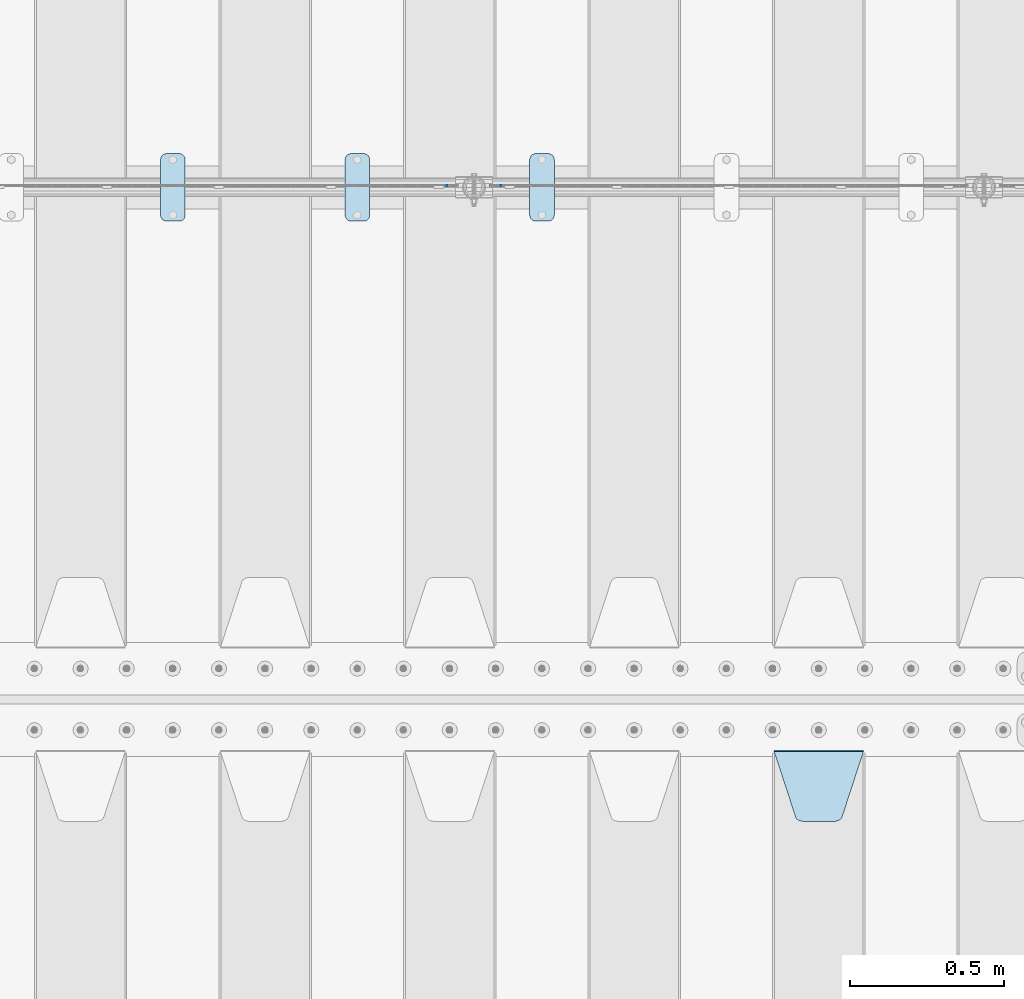
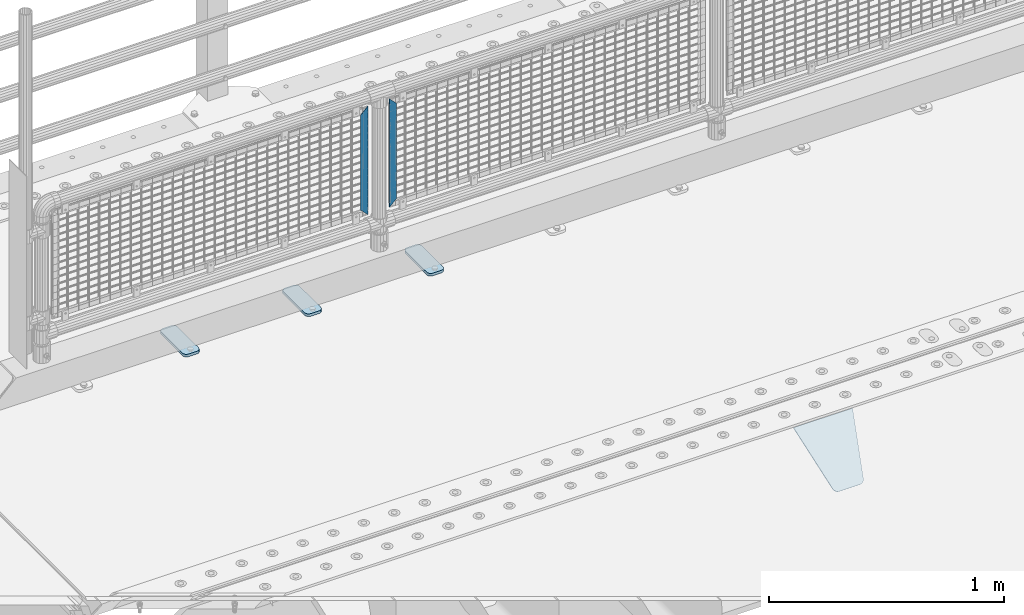
# One storey, part 211 of 240: 6 plates.
"""IFC2X3 building model written with IfcOpenShell, lengths in millimetres."""

import ifcopenshell
import ifcopenshell.guid

model = None  # the IFC model being written
_history = None  # IfcOwnerHistory: only IFC2X3 demands one
_inside = {}  # id of a spatial element -> (the spatial element, [elements in it])
_under = {}  # id of a project, library or spatial element -> (it, [spatial elements below it])
_declared = {}  # id of a project -> (the project, [libraries it declares])
_typed = {}  # id of a type object -> (the type object, [elements of that type])
_made_of = {}  # id of a material, layer set ... -> (it, [elements and type objects made of it])


def new_model(schema):
    """Start an empty IFC model of exactly this schema.

    Asked for "IFC4X3", IfcOpenShell would pick the latest addendum, in which some entities
    have other attributes; the version numbers below select the first issue.
    IFC2X3 requires an IfcOwnerHistory on every rooted entity: one is made here for all.
    """
    global model, _history
    if schema == "IFC4X3":
        model = ifcopenshell.file(schema_version=(4, 3, 0, 0))
    else:
        model = ifcopenshell.file(schema=schema)
    _inside.clear()
    _under.clear()
    _declared.clear()
    _typed.clear()
    _made_of.clear()
    _history = None
    if model.schema == "IFC2X3":
        org = make("IfcOrganization", Name="unknown")
        user = make(
            "IfcPersonAndOrganization",
            ThePerson=make("IfcPerson", FamilyName="unknown"),
            TheOrganization=org,
        )
        app = make(
            "IfcApplication",
            ApplicationDeveloper=org,
            Version="unknown",
            ApplicationFullName="unknown",
            ApplicationIdentifier="unknown",
        )
        _history = make(
            "IfcOwnerHistory",
            OwningUser=user,
            OwningApplication=app,
            ChangeAction="ADDED",
            CreationDate=0,
        )
    return model


def make(cls, **values):
    """One entity of the class cls with the attributes given. An attribute that is None is left unset."""
    return model.create_entity(
        cls, **{name: value for name, value in values.items() if value is not None}
    )


def rooted(cls, **values):
    """An entity with a GlobalId (a new one), such as an element, a storey or a relation."""
    return make(cls, GlobalId=ifcopenshell.guid.new(), OwnerHistory=_history, **values)


def si_unit(unit_type, name, prefix=None):
    """IfcSIUnit, for example si_unit("LENGTHUNIT", "METRE", prefix="MILLI")."""
    return make("IfcSIUnit", UnitType=unit_type, Prefix=prefix, Name=name)


def assignment(units):
    """IfcUnitAssignment: the units of a project."""
    return None if units is None else make("IfcUnitAssignment", Units=units)


def point(xyz):
    """IfcCartesianPoint."""
    return None if xyz is None else make("IfcCartesianPoint", Coordinates=xyz)


def direction(xyz):
    """IfcDirection."""
    return None if xyz is None else make("IfcDirection", DirectionRatios=xyz)


def frame(location, z_axis=None, x_axis=None):
    """IfcAxis2Placement3D, a coordinate frame: its origin and axes. An axis left out is left unset."""
    return make(
        "IfcAxis2Placement3D",
        Location=point(location),
        Axis=direction(z_axis),
        RefDirection=direction(x_axis),
    )


def origin_with_axes():
    """The frame at (0, 0, 0) with the z axis (0, 0, 1) and the x axis (1, 0, 0) written out."""
    return frame((0.0, 0.0, 0.0), z_axis=(0.0, 0.0, 1.0), x_axis=(1.0, 0.0, 0.0))


def place(relative_to, where):
    """IfcLocalPlacement: puts the frame where relative to a parent placement (None: the world)."""
    return make(
        "IfcLocalPlacement", PlacementRelTo=relative_to, RelativePlacement=where
    )


def context(
    kind, dimensions, precision=None, world=None, true_north=None, identifier=None
):
    """IfcGeometricRepresentationContext, for example the 3D "Model" context."""
    return make(
        "IfcGeometricRepresentationContext",
        ContextIdentifier=identifier,
        ContextType=kind,
        CoordinateSpaceDimension=dimensions,
        Precision=precision,
        WorldCoordinateSystem=world,
        TrueNorth=true_north,
    )


def subcontext(parent, identifier, kind, view, scale=None):
    """IfcGeometricRepresentationSubContext, for example "Body" below "Model"."""
    return make(
        "IfcGeometricRepresentationSubContext",
        ContextIdentifier=identifier,
        ContextType=kind,
        ParentContext=parent,
        TargetScale=scale,
        TargetView=view,
    )


def project(units=None, contexts=None):
    """IfcProject with its units and contexts."""
    return rooted(
        "IfcProject",
        Name="project",
        RepresentationContexts=contexts,
        UnitsInContext=assignment(units),
    )


def spatial(cls, under=None, at=None, **own):
    """A site, building, storey or space (cls), placed at a placement, below another one or the project."""
    s = rooted(cls, ObjectPlacement=at, **own)
    if under is not None:
        _under.setdefault(under.id(), (under, []))[1].append(s)
    return s


def faces_of(points, faces, orient=None, outer=None):
    """IfcFace entities. A face is a list of loops; a loop is a list of indices into points, from 0.

    orient and outer hold one flag for each loop. By default every Orientation is true, the
    first loop of a face is its IfcFaceOuterBound and the others are IfcFaceBound.
    """
    made = []
    for i, loops in enumerate(faces):
        bounds = []
        for j, loop in enumerate(loops):
            is_outer = j == 0 if outer is None else outer[i][j]
            bounds.append(
                make(
                    "IfcFaceOuterBound" if is_outer else "IfcFaceBound",
                    Bound=make("IfcPolyLoop", Polygon=[points[k] for k in loop]),
                    Orientation=True if orient is None else orient[i][j],
                )
            )
        made.append(make("IfcFace", Bounds=bounds))
    return made


def faceted_brep(points, faces, orient=None, outer=None, voids=None):
    """IfcFacetedBrep: a solid bounded by flat faces; with voids (closed shells), ...WithVoids."""
    shared = [point(p) for p in points]
    hull = make("IfcClosedShell", CfsFaces=faces_of(shared, faces, orient, outer))
    if voids is None:
        return make("IfcFacetedBrep", Outer=hull)
    return make(
        "IfcFacetedBrepWithVoids",
        Outer=hull,
        Voids=[
            make(cls, CfsFaces=faces_of(shared, fs, o, b)) for cls, fs, o, b in voids
        ],
    )


def shape(context_of_items, identifier, shape_type, items):
    """IfcShapeRepresentation: the items that make up one representation, for example the "Body"."""
    return make(
        "IfcShapeRepresentation",
        ContextOfItems=context_of_items,
        RepresentationIdentifier=identifier,
        RepresentationType=shape_type,
        Items=items,
    )


def material(Name=None, Category=None):
    """IfcMaterial."""
    return make("IfcMaterial", Name=Name, Category=Category)


def made_of(thing, what):
    """Note that an element or type object is made of a material, layer set ...; save() writes the relation."""
    if what is not None:
        _made_of.setdefault(what.id(), (what, []))[1].append(thing)
    return thing


def type_object(cls, material=None, **own):
    """A type object (cls), such as IfcWallType, which elements share."""
    return made_of(rooted(cls, **own), material)


def element(
    cls,
    number,
    at=None,
    inside=None,
    cuts=None,
    type_object=None,
    material=None,
    context=None,
    identifier="Body",
    shape_type=None,
    held_by="IfcProductDefinitionShape",
    body=None,
    shapes=None,
    **own,
):
    """One element of the class cls, such as IfcWall. Its Tag is "e" and its number.

    at: its placement. inside: the storey or other place that contains it. cuts: it is an
    opening in that element (IfcRelVoidsElement). A single representation is given by context,
    identifier, shape_type and body (its items); several are given by shapes. held_by: the class
    of the entity that holds the representations. save() writes the other relations.
    """
    e = rooted(cls, Tag="e%d" % number, ObjectPlacement=at, **own)
    if body is not None:
        shapes = [shape(context, identifier, shape_type, body)]
    if shapes is not None:
        e.Representation = make(held_by, Representations=shapes)
    if inside is not None:
        _inside.setdefault(inside.id(), (inside, []))[1].append(e)
    if cuts is not None:
        rooted(
            "IfcRelVoidsElement", RelatingBuildingElement=cuts, RelatedOpeningElement=e
        )
    if type_object is not None:
        _typed.setdefault(type_object.id(), (type_object, []))[1].append(e)
    return made_of(e, material)


def aggregate(whole, parts):
    """IfcRelAggregates: a whole, such as a stair, and the parts it consists of."""
    return rooted("IfcRelAggregates", RelatingObject=whole, RelatedObjects=parts)


def save(model, path):
    """Write the relations noted so far, then the file.

    IfcRelAggregates (storeys below a building ...), IfcRelContainedInSpatialStructure (elements
    in a storey), IfcRelDefinesByType, IfcRelAssociatesMaterial and IfcRelDeclares: one each for
    every whole, place, type object, material and project.
    """
    for whole, parts in _under.values():
        aggregate(whole, parts)
    for where, things in _inside.values():
        rooted(
            "IfcRelContainedInSpatialStructure",
            RelatedElements=things,
            RelatingStructure=where,
        )
    for kind, things in _typed.values():
        rooted("IfcRelDefinesByType", RelatedObjects=things, RelatingType=kind)
    for what, things in _made_of.values():
        rooted("IfcRelAssociatesMaterial", RelatedObjects=things, RelatingMaterial=what)
    for by, libraries in _declared.values():
        rooted("IfcRelDeclares", RelatingContext=by, RelatedDefinitions=libraries)
    model.write(path)


model = new_model("IFC2X3")

# Units and contexts
model_context = context("Model", 3, precision=1e-05, world=origin_with_axes())
body_context = subcontext(model_context, "Body", "Model", "MODEL_VIEW")
ifc_project = project(units=[si_unit("LENGTHUNIT", "METRE", prefix="MILLI"), si_unit("AREAUNIT", "SQUARE_METRE"), si_unit("VOLUMEUNIT", "CUBIC_METRE"), si_unit("MASSUNIT", "GRAM", prefix="KILO"), si_unit("TIMEUNIT", "SECOND"), si_unit("PLANEANGLEUNIT", "RADIAN"), si_unit("SOLIDANGLEUNIT", "STERADIAN"), si_unit("THERMODYNAMICTEMPERATUREUNIT", "DEGREE_CELSIUS"), si_unit("LUMINOUSINTENSITYUNIT", "LUMEN")], contexts=[model_context])

# Site, building, storey
site_placement = place(None, origin_with_axes())
site = spatial("IfcSite", under=ifc_project, at=site_placement, CompositionType="ELEMENT")
building_placement = place(site_placement, origin_with_axes())
building = spatial("IfcBuilding", under=site, at=building_placement, Name="Standard", CompositionType="ELEMENT")
storey_placement = place(building_placement, origin_with_axes())
storey = spatial("IfcBuildingStorey", under=building, at=storey_placement, Name="Undefined", CompositionType="ELEMENT", Elevation=0.0)

# Plates
ifc_material_1 = material(Name="STEEL/S355N")
plate_type_1 = type_object("IfcPlateType", PredefinedType="NOTDEFINED")
plate_1_placement = place(storey_placement, frame((45705.0, 32831.767766956, -1.76776695296758), z_axis=(0.0, -0.707106781186547, -0.707106781186548), x_axis=(1.0, 0.0, 0.0)))
element("IfcPlate", 1, at=plate_1_placement, inside=storey, type_object=plate_type_1, material=ifc_material_1, context=body_context, shape_type="Brep", body=[
    faceted_brep([(0.0, -2.5, 0.0), (69.345504679477, -2.50000000000364, 300.171731424827), (69.345504679477, 2.49999999999636, 300.171731424827), (0.0, 2.5, 0.0), (70.927406119954, -2.50000000000364, 304.897442415397), (70.927406119954, 2.49999999999636, 304.897442415397), (73.3818627772271, -2.50000000000728, 309.234538108525), (73.3818627772271, 2.49999999999636, 309.234538108529), (76.6187032999587, -2.50000000000728, 313.023683126099), (76.6187032999587, 2.49999999999636, 313.023683126103), (80.5190132705029, -2.50000000000364, 316.125672595368), (80.5190132705029, 2.49999999999636, 316.125672595368), (84.9395038596849, -2.50000000000364, 318.426546230472), (84.9395038596849, 2.49999999999636, 318.426546230472), (89.7177759439219, -2.5, 319.841774983277), (89.7177759439219, 2.49999999999636, 319.841774983273), (94.6782862926484, -2.50000000000364, 320.319366455074), (94.6782862926484, 2.49999999999636, 320.319366455074), (195.321713707352, -2.50000000000364, 320.319366455074), (195.321713707352, 2.49999999999636, 320.319366455074), (200.282224056078, -2.50000000000364, 319.841774983273), (200.282224056078, 2.49999999999636, 319.841774983273), (205.060496140315, -2.50000000000364, 318.426546230472), (205.060496140315, 2.49999999999636, 318.426546230472), (209.480986729497, -2.50000000000364, 316.125672595368), (209.480986729497, 2.49999999999636, 316.125672595368), (213.381296700041, -2.50000000000728, 313.023683126099), (213.381296700041, 2.49999999999272, 313.023683126099), (216.618137222766, -2.50000000000364, 309.234538108522), (216.618137222766, 2.49999999999636, 309.234538108522), (219.072593880039, -2.50000000000364, 304.897442415397), (219.072593880039, 2.49999999999636, 304.897442415397), (220.654495320523, -2.50000000000364, 300.171731424827), (220.654495320523, 2.49999999999636, 300.171731424827), (290.0, -2.50000000000364, -3.63797880709171e-12), (290.0, 2.49999999999636, -3.63797880709171e-12)], [[[0, 1, 2, 3]], [[1, 4, 5, 2]], [[4, 6, 7, 5]], [[6, 8, 9, 7]], [[8, 10, 11, 9]], [[10, 12, 13, 11]], [[12, 14, 15, 13]], [[14, 16, 17, 15]], [[16, 18, 19, 17]], [[18, 20, 21, 19]], [[20, 22, 23, 21]], [[22, 24, 25, 23]], [[24, 26, 27, 25]], [[26, 28, 29, 27]], [[28, 30, 31, 29]], [[30, 32, 33, 31]], [[32, 34, 35, 33]], [[34, 0, 3, 35]], [[5, 7, 9, 11, 13, 15, 17, 19, 21, 23, 25, 27, 29, 31, 33, 35, 3, 2]], [[34, 32, 30, 28, 26, 24, 22, 20, 18, 16, 14, 12, 10, 8, 6, 4, 1, 0]]]),
])
ifc_material_2 = material(Name="STEEL/S355J2")
plate_type_2 = type_object("IfcPlateType", PredefinedType="NOTDEFINED")
plate_2_placement = place(storey_placement, frame((44910.0, 34774.5, 21.0199999999977), z_axis=(1.0, 0.0, 0.0), x_axis=(0.0, -1.0, 0.0)))
element("IfcPlate", 2, at=plate_2_placement, inside=storey, type_object=plate_type_2, material=ifc_material_2, context=body_context, shape_type="Brep", body=[
    faceted_brep([(0.0, -7.0, 20.0), (0.0, -7.0, 60.0), (0.0, 7.0, 60.0), (0.0, 7.0, 20.0), (0.384294391937146, -7.0, 63.9018064403208), (0.384294391937146, 7.0, 63.9018064403208), (1.52240934977453, -7.0, 67.6536686473046), (1.52240934977453, 7.0, 67.6536686473046), (3.37060775394639, -7.0, 71.1114046603907), (3.37060775394639, 7.0, 71.1114046603907), (5.85786437626666, -7.0, 74.1421356237333), (5.85786437626666, 7.0, 74.1421356237333), (8.88859533960931, -7.0, 76.6293922460536), (8.88859533960931, 7.0, 76.6293922460536), (12.3463313526954, -7.0, 78.4775906502255), (12.3463313526954, 7.0, 78.4775906502255), (16.0981935596792, -7.0, 79.6157056080629), (16.0981935596792, 7.0, 79.6157056080629), (20.0, -7.0, 80.0), (20.0, 7.0, 80.0), (200.0, -7.0, 80.0), (200.0, 7.0, 80.0), (203.901806440321, -7.0, 79.6157056080629), (203.901806440321, 7.0, 79.6157056080629), (207.653668647305, -7.0, 78.4775906502255), (207.653668647305, 7.0, 78.4775906502255), (211.111404660391, -7.0, 76.6293922460536), (211.111404660391, 7.0, 76.6293922460536), (214.142135623733, -7.0, 74.1421356237333), (214.142135623733, 7.0, 74.1421356237333), (216.629392246054, -7.0, 71.1114046603907), (216.629392246054, 7.0, 71.1114046603907), (218.477590650225, -7.0, 67.6536686473046), (218.477590650225, 7.0, 67.6536686473046), (219.615705608063, -7.0, 63.9018064403208), (219.615705608063, 7.0, 63.9018064403208), (220.0, -7.0, 60.0), (220.0, 7.0, 60.0), (220.0, -7.0, 20.0), (220.0, 7.0, 20.0), (219.615705608063, -7.0, 16.0981935596792), (219.615705608063, 7.0, 16.0981935596792), (218.477590650225, -7.0, 12.3463313526954), (218.477590650225, 7.0, 12.3463313526954), (216.629392246054, -7.0, 8.88859533960931), (216.629392246054, 7.0, 8.88859533960931), (214.142135623733, -7.0, 5.85786437626666), (214.142135623733, 7.0, 5.85786437626666), (211.111404660391, -7.0, 3.37060775394639), (211.111404660391, 7.0, 3.37060775394639), (207.653668647305, -7.0, 1.52240934977453), (207.653668647305, 7.0, 1.52240934977453), (203.901806440321, -7.0, 0.384294391937146), (203.901806440321, 7.0, 0.384294391937146), (200.0, -7.0, 0.0), (200.0, 7.0, 0.0), (20.0, -7.0, 0.0), (20.0, 7.0, 0.0), (16.0981935596792, -7.0, 0.384294391937146), (16.0981935596792, 7.0, 0.384294391937146), (12.3463313526954, -7.0, 1.52240934977453), (12.3463313526954, 7.0, 1.52240934977453), (8.88859533960931, -7.0, 3.37060775394639), (8.88859533960931, 7.0, 3.37060775394639), (5.85786437626666, -7.0, 5.85786437626666), (5.85786437626666, 7.0, 5.85786437626666), (3.37060775394639, -7.0, 8.88859533960931), (3.37060775394639, 7.0, 8.88859533960931), (1.52240934977453, -7.0, 12.3463313526954), (1.52240934977453, 7.0, 12.3463313526954), (0.384294391937146, -7.0, 16.0981935596792), (0.384294391937146, 7.0, 16.0981935596792)], [[[0, 1, 2, 3]], [[1, 4, 5, 2]], [[4, 6, 7, 5]], [[6, 8, 9, 7]], [[8, 10, 11, 9]], [[10, 12, 13, 11]], [[12, 14, 15, 13]], [[14, 16, 17, 15]], [[16, 18, 19, 17]], [[18, 20, 21, 19]], [[20, 22, 23, 21]], [[22, 24, 25, 23]], [[24, 26, 27, 25]], [[26, 28, 29, 27]], [[28, 30, 31, 29]], [[30, 32, 33, 31]], [[32, 34, 35, 33]], [[34, 36, 37, 35]], [[36, 38, 39, 37]], [[38, 40, 41, 39]], [[40, 42, 43, 41]], [[42, 44, 45, 43]], [[44, 46, 47, 45]], [[46, 48, 49, 47]], [[48, 50, 51, 49]], [[50, 52, 53, 51]], [[52, 54, 55, 53]], [[54, 56, 57, 55]], [[56, 58, 59, 57]], [[58, 60, 61, 59]], [[60, 62, 63, 61]], [[62, 64, 65, 63]], [[64, 66, 67, 65]], [[66, 68, 69, 67]], [[68, 70, 71, 69]], [[70, 0, 3, 71]], [[5, 7, 9, 11, 13, 15, 17, 19, 21, 23, 25, 27, 29, 31, 33, 35, 37, 39, 41, 43, 45, 47, 49, 51, 53, 55, 57, 59, 61, 63, 65, 67, 69, 71, 3, 2]], [[70, 68, 66, 64, 62, 60, 58, 56, 54, 52, 50, 48, 46, 44, 42, 40, 38, 36, 34, 32, 30, 28, 26, 24, 22, 20, 18, 16, 14, 12, 10, 8, 6, 4, 1, 0]]]),
])
plate_3_placement = place(storey_placement, frame((44310.0, 34774.5, 21.0199999999977), z_axis=(1.0, 0.0, 0.0), x_axis=(0.0, -1.0, 0.0)))
element("IfcPlate", 3, at=plate_3_placement, inside=storey, type_object=plate_type_2, material=ifc_material_2, context=body_context, shape_type="Brep", body=[
    faceted_brep([(0.0, -7.0, 20.0), (0.0, -7.0, 60.0), (0.0, 7.0, 60.0), (0.0, 7.0, 20.0), (0.384294391937146, -7.0, 63.9018064403208), (0.384294391937146, 7.0, 63.9018064403208), (1.52240934977453, -7.0, 67.6536686473046), (1.52240934977453, 7.0, 67.6536686473046), (3.37060775394639, -7.0, 71.1114046603907), (3.37060775394639, 7.0, 71.1114046603907), (5.85786437626666, -7.0, 74.1421356237333), (5.85786437626666, 7.0, 74.1421356237333), (8.88859533960931, -7.0, 76.6293922460536), (8.88859533960931, 7.0, 76.6293922460536), (12.3463313526954, -7.0, 78.4775906502255), (12.3463313526954, 7.0, 78.4775906502255), (16.0981935596792, -7.0, 79.6157056080629), (16.0981935596792, 7.0, 79.6157056080629), (20.0, -7.0, 80.0), (20.0, 7.0, 80.0), (200.0, -7.0, 80.0), (200.0, 7.0, 80.0), (203.901806440321, -7.0, 79.6157056080629), (203.901806440321, 7.0, 79.6157056080629), (207.653668647305, -7.0, 78.4775906502255), (207.653668647305, 7.0, 78.4775906502255), (211.111404660391, -7.0, 76.6293922460536), (211.111404660391, 7.0, 76.6293922460536), (214.142135623733, -7.0, 74.1421356237333), (214.142135623733, 7.0, 74.1421356237333), (216.629392246054, -7.0, 71.1114046603907), (216.629392246054, 7.0, 71.1114046603907), (218.477590650225, -7.0, 67.6536686473046), (218.477590650225, 7.0, 67.6536686473046), (219.615705608063, -7.0, 63.9018064403208), (219.615705608063, 7.0, 63.9018064403208), (220.0, -7.0, 60.0), (220.0, 7.0, 60.0), (220.0, -7.0, 20.0), (220.0, 7.0, 20.0), (219.615705608063, -7.0, 16.0981935596792), (219.615705608063, 7.0, 16.0981935596792), (218.477590650225, -7.0, 12.3463313526954), (218.477590650225, 7.0, 12.3463313526954), (216.629392246054, -7.0, 8.88859533960931), (216.629392246054, 7.0, 8.88859533960931), (214.142135623733, -7.0, 5.85786437626666), (214.142135623733, 7.0, 5.85786437626666), (211.111404660391, -7.0, 3.37060775394639), (211.111404660391, 7.0, 3.37060775394639), (207.653668647305, -7.0, 1.52240934977453), (207.653668647305, 7.0, 1.52240934977453), (203.901806440321, -7.0, 0.384294391937146), (203.901806440321, 7.0, 0.384294391937146), (200.0, -7.0, 0.0), (200.0, 7.0, 0.0), (20.0, -7.0, 0.0), (20.0, 7.0, 0.0), (16.0981935596792, -7.0, 0.384294391937146), (16.0981935596792, 7.0, 0.384294391937146), (12.3463313526954, -7.0, 1.52240934977453), (12.3463313526954, 7.0, 1.52240934977453), (8.88859533960931, -7.0, 3.37060775394639), (8.88859533960931, 7.0, 3.37060775394639), (5.85786437626666, -7.0, 5.85786437626666), (5.85786437626666, 7.0, 5.85786437626666), (3.37060775394639, -7.0, 8.88859533960931), (3.37060775394639, 7.0, 8.88859533960931), (1.52240934977453, -7.0, 12.3463313526954), (1.52240934977453, 7.0, 12.3463313526954), (0.384294391937146, -7.0, 16.0981935596792), (0.384294391937146, 7.0, 16.0981935596792)], [[[0, 1, 2, 3]], [[1, 4, 5, 2]], [[4, 6, 7, 5]], [[6, 8, 9, 7]], [[8, 10, 11, 9]], [[10, 12, 13, 11]], [[12, 14, 15, 13]], [[14, 16, 17, 15]], [[16, 18, 19, 17]], [[18, 20, 21, 19]], [[20, 22, 23, 21]], [[22, 24, 25, 23]], [[24, 26, 27, 25]], [[26, 28, 29, 27]], [[28, 30, 31, 29]], [[30, 32, 33, 31]], [[32, 34, 35, 33]], [[34, 36, 37, 35]], [[36, 38, 39, 37]], [[38, 40, 41, 39]], [[40, 42, 43, 41]], [[42, 44, 45, 43]], [[44, 46, 47, 45]], [[46, 48, 49, 47]], [[48, 50, 51, 49]], [[50, 52, 53, 51]], [[52, 54, 55, 53]], [[54, 56, 57, 55]], [[56, 58, 59, 57]], [[58, 60, 61, 59]], [[60, 62, 63, 61]], [[62, 64, 65, 63]], [[64, 66, 67, 65]], [[66, 68, 69, 67]], [[68, 70, 71, 69]], [[70, 0, 3, 71]], [[5, 7, 9, 11, 13, 15, 17, 19, 21, 23, 25, 27, 29, 31, 33, 35, 37, 39, 41, 43, 45, 47, 49, 51, 53, 55, 57, 59, 61, 63, 65, 67, 69, 71, 3, 2]], [[70, 68, 66, 64, 62, 60, 58, 56, 54, 52, 50, 48, 46, 44, 42, 40, 38, 36, 34, 32, 30, 28, 26, 24, 22, 20, 18, 16, 14, 12, 10, 8, 6, 4, 1, 0]]]),
])
plate_4_placement = place(storey_placement, frame((43710.0, 34774.5, 21.0199999999977), z_axis=(1.0, 0.0, 0.0), x_axis=(0.0, -1.0, 0.0)))
element("IfcPlate", 4, at=plate_4_placement, inside=storey, type_object=plate_type_2, material=ifc_material_2, context=body_context, shape_type="Brep", body=[
    faceted_brep([(0.0, -7.0, 20.0), (0.0, -7.0, 60.0), (0.0, 7.0, 60.0), (0.0, 7.0, 20.0), (0.384294391937146, -7.0, 63.9018064403208), (0.384294391937146, 7.0, 63.9018064403208), (1.52240934977453, -7.0, 67.6536686473046), (1.52240934977453, 7.0, 67.6536686473046), (3.37060775394639, -7.0, 71.1114046603907), (3.37060775394639, 7.0, 71.1114046603907), (5.85786437626666, -7.0, 74.1421356237333), (5.85786437626666, 7.0, 74.1421356237333), (8.88859533960931, -7.0, 76.6293922460536), (8.88859533960931, 7.0, 76.6293922460536), (12.3463313526954, -7.0, 78.4775906502255), (12.3463313526954, 7.0, 78.4775906502255), (16.0981935596792, -7.0, 79.6157056080629), (16.0981935596792, 7.0, 79.6157056080629), (20.0, -7.0, 80.0), (20.0, 7.0, 80.0), (200.0, -7.0, 80.0), (200.0, 7.0, 80.0), (203.901806440321, -7.0, 79.6157056080629), (203.901806440321, 7.0, 79.6157056080629), (207.653668647305, -7.0, 78.4775906502255), (207.653668647305, 7.0, 78.4775906502255), (211.111404660391, -7.0, 76.6293922460536), (211.111404660391, 7.0, 76.6293922460536), (214.142135623733, -7.0, 74.1421356237333), (214.142135623733, 7.0, 74.1421356237333), (216.629392246054, -7.0, 71.1114046603907), (216.629392246054, 7.0, 71.1114046603907), (218.477590650225, -7.0, 67.6536686473046), (218.477590650225, 7.0, 67.6536686473046), (219.615705608063, -7.0, 63.9018064403208), (219.615705608063, 7.0, 63.9018064403208), (220.0, -7.0, 60.0), (220.0, 7.0, 60.0), (220.0, -7.0, 20.0), (220.0, 7.0, 20.0), (219.615705608063, -7.0, 16.0981935596792), (219.615705608063, 7.0, 16.0981935596792), (218.477590650225, -7.0, 12.3463313526954), (218.477590650225, 7.0, 12.3463313526954), (216.629392246054, -7.0, 8.88859533960931), (216.629392246054, 7.0, 8.88859533960931), (214.142135623733, -7.0, 5.85786437626666), (214.142135623733, 7.0, 5.85786437626666), (211.111404660391, -7.0, 3.37060775394639), (211.111404660391, 7.0, 3.37060775394639), (207.653668647305, -7.0, 1.52240934977453), (207.653668647305, 7.0, 1.52240934977453), (203.901806440321, -7.0, 0.384294391937146), (203.901806440321, 7.0, 0.384294391937146), (200.0, -7.0, 0.0), (200.0, 7.0, 0.0), (20.0, -7.0, 0.0), (20.0, 7.0, 0.0), (16.0981935596792, -7.0, 0.384294391937146), (16.0981935596792, 7.0, 0.384294391937146), (12.3463313526954, -7.0, 1.52240934977453), (12.3463313526954, 7.0, 1.52240934977453), (8.88859533960931, -7.0, 3.37060775394639), (8.88859533960931, 7.0, 3.37060775394639), (5.85786437626666, -7.0, 5.85786437626666), (5.85786437626666, 7.0, 5.85786437626666), (3.37060775394639, -7.0, 8.88859533960931), (3.37060775394639, 7.0, 8.88859533960931), (1.52240934977453, -7.0, 12.3463313526954), (1.52240934977453, 7.0, 12.3463313526954), (0.384294391937146, -7.0, 16.0981935596792), (0.384294391937146, 7.0, 16.0981935596792)], [[[0, 1, 2, 3]], [[1, 4, 5, 2]], [[4, 6, 7, 5]], [[6, 8, 9, 7]], [[8, 10, 11, 9]], [[10, 12, 13, 11]], [[12, 14, 15, 13]], [[14, 16, 17, 15]], [[16, 18, 19, 17]], [[18, 20, 21, 19]], [[20, 22, 23, 21]], [[22, 24, 25, 23]], [[24, 26, 27, 25]], [[26, 28, 29, 27]], [[28, 30, 31, 29]], [[30, 32, 33, 31]], [[32, 34, 35, 33]], [[34, 36, 37, 35]], [[36, 38, 39, 37]], [[38, 40, 41, 39]], [[40, 42, 43, 41]], [[42, 44, 45, 43]], [[44, 46, 47, 45]], [[46, 48, 49, 47]], [[48, 50, 51, 49]], [[50, 52, 53, 51]], [[52, 54, 55, 53]], [[54, 56, 57, 55]], [[56, 58, 59, 57]], [[58, 60, 61, 59]], [[60, 62, 63, 61]], [[62, 64, 65, 63]], [[64, 66, 67, 65]], [[66, 68, 69, 67]], [[68, 70, 71, 69]], [[70, 0, 3, 71]], [[5, 7, 9, 11, 13, 15, 17, 19, 21, 23, 25, 27, 29, 31, 33, 35, 37, 39, 41, 43, 45, 47, 49, 51, 53, 55, 57, 59, 61, 63, 65, 67, 69, 71, 3, 2]], [[70, 68, 66, 64, 62, 60, 58, 56, 54, 52, 50, 48, 46, 44, 42, 40, 38, 36, 34, 32, 30, 28, 26, 24, 22, 20, 18, 16, 14, 12, 10, 8, 6, 4, 1, 0]]]),
])
ifc_material_3 = material(Name="Misc_Undefined")
plate_type_3 = type_object("IfcPlateType", PredefinedType="NOTDEFINED")
plate_5_placement = place(storey_placement, frame((44817.509713541, 34670.5, 879.519963133601), z_axis=(-0.707008801899317, 0.0, -0.707204746899292), x_axis=(-0.707204746899293, 0.0, 0.707008801899317)))
element("IfcPlate", 5, at=plate_5_placement, inside=storey, type_object=plate_type_3, material=ifc_material_3, context=body_context, shape_type="Brep", body=[
    faceted_brep([(-7.27595761418343e-12, -1.49999999999272, 0.0), (-348.552185058594, -1.5, 348.65502929686), (-348.552185058594, 1.5, 348.65502929686), (0.0, 1.50000000000728, 0.0), (-348.544891357415, -1.5, 398.152496337883), (-348.544891357415, 1.5, 398.152496337883), (49.5043945312573, -1.5, 6.54836185276508e-11), (49.5043945312573, 1.5, 6.54836185276508e-11)], [[[0, 1, 2, 3]], [[1, 4, 5, 2]], [[4, 6, 7, 5]], [[6, 0, 3, 7]], [[5, 7, 3, 2]], [[6, 4, 1, 0]]]),
])
plate_6_placement = place(storey_placement, frame((44640.4996874836, 34670.5, 879.52), z_axis=(0.707103624179501, 0.0, -0.707109938179499), x_axis=(0.707109938179525, 0.0, 0.707103624179475)))
element("IfcPlate", 6, at=plate_6_placement, inside=storey, type_object=plate_type_3, material=ifc_material_3, context=body_context, shape_type="Brep", body=[
    faceted_brep([(-7.27595761418343e-12, -1.49999999999272, 0.0), (-348.605163574233, -1.5, 348.602081298821), (-348.605163574233, 1.5, 348.602081298821), (0.0, 1.50000000000728, 0.0), (-348.605163574226, -1.5, 398.099334716797), (-348.605163574226, 1.5, 398.099334716797), (49.4976959228443, -1.5, -1.09139364212751e-10), (49.4976959228443, 1.5, -1.09139364212751e-10)], [[[0, 1, 2, 3]], [[1, 4, 5, 2]], [[4, 6, 7, 5]], [[6, 0, 3, 7]], [[5, 7, 3, 2]], [[6, 4, 1, 0]]]),
])

save(model, "model.ifc")
